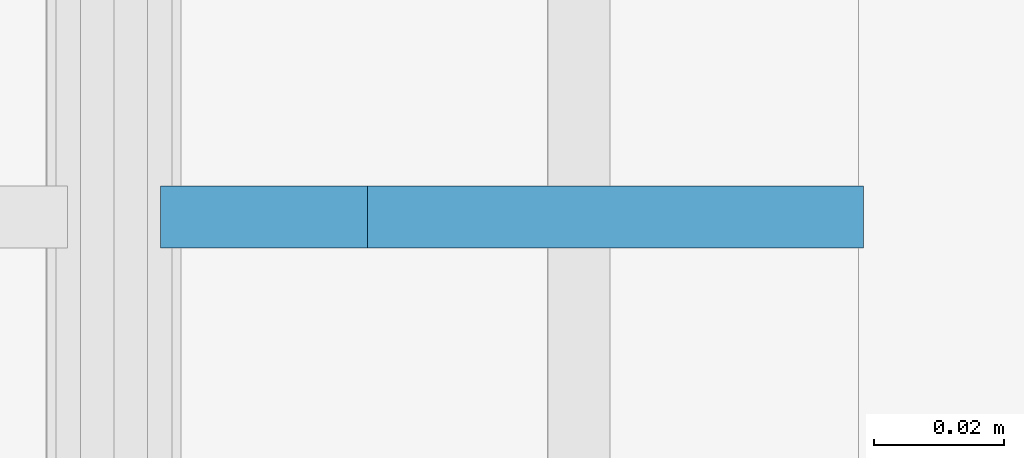
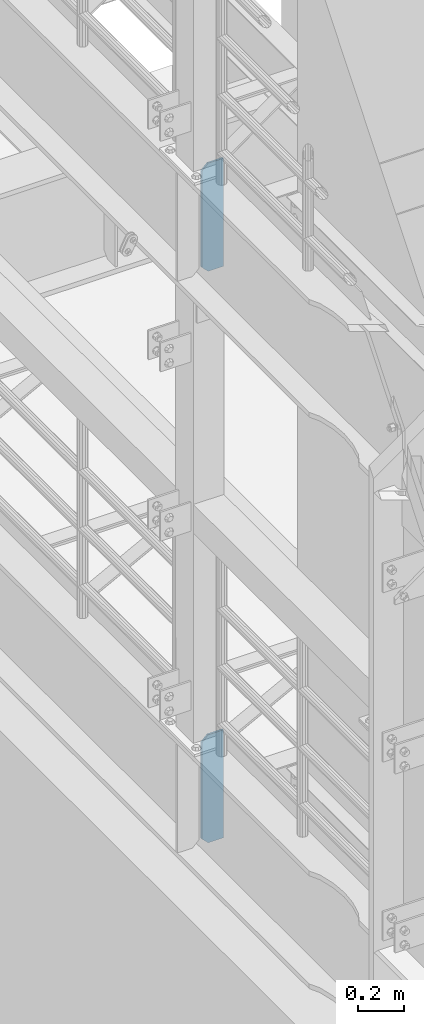
# One storey, part 1597 of 1876: 2 plates, 2 elements without a shape of their own.
"""IFC2X3 building model written with IfcOpenShell, lengths in millimetres."""

from ifc_helpers import new_model, si_unit, frame, origin_with_axes, place, context, subcontext, project, spatial, faceted_brep, material, type_object, element, aggregate, save


model = new_model("IFC2X3")

# Units and contexts
model_context = context("Model", 3, precision=1e-05, world=origin_with_axes())
body_context = subcontext(model_context, "Body", "Model", "MODEL_VIEW")
ifc_project = project(units=[si_unit("LENGTHUNIT", "METRE", prefix="MILLI"), si_unit("AREAUNIT", "SQUARE_METRE"), si_unit("VOLUMEUNIT", "CUBIC_METRE"), si_unit("MASSUNIT", "GRAM", prefix="KILO"), si_unit("TIMEUNIT", "SECOND"), si_unit("PLANEANGLEUNIT", "RADIAN"), si_unit("SOLIDANGLEUNIT", "STERADIAN"), si_unit("THERMODYNAMICTEMPERATUREUNIT", "DEGREE_CELSIUS"), si_unit("LUMINOUSINTENSITYUNIT", "LUMEN")], contexts=[model_context])

# Site, building, storey
site_placement = place(None, origin_with_axes())
site = spatial("IfcSite", under=ifc_project, at=site_placement, CompositionType="ELEMENT")
building_placement = place(site_placement, origin_with_axes())
building = spatial("IfcBuilding", under=site, at=building_placement, Name="Undefined", CompositionType="ELEMENT")
storey_placement = place(building_placement, origin_with_axes())
storey = spatial("IfcBuildingStorey", under=building, at=storey_placement, Name="Undefined", CompositionType="ELEMENT", Elevation=0.0)

# Assembly, plate
assembly_1_placement = place(storey_placement, origin_with_axes())
assembly_1 = element("IfcElementAssembly", 1, at=assembly_1_placement, inside=storey, Name="BEAM", AssemblyPlace="NOTDEFINED", PredefinedType="RIGID_FRAME")
ifc_material = material(Name="STEEL/A36")
plate_type = type_object("IfcPlateType", PredefinedType="NOTDEFINED")
plate_1_placement = place(assembly_1_placement, frame((115.09375, 3556.0, 7556.5), z_axis=(0.0, 0.0, 1.0), x_axis=(-1.0, 0.0, 0.0)))
plate_1 = element("IfcPlate", 2, at=plate_1_placement, type_object=plate_type, material=ifc_material, Name="PLATE", context=body_context, shape_type="Brep", body=[
    faceted_brep([(0.0, -4.76249999999982, 0.0), (0.0, -4.76249999999982, 571.5), (0.0, 4.76249999999982, 571.5), (0.0, 4.76249999999982, 0.0), (76.1999969482422, -4.76249999999982, 571.5), (76.1999969482422, 4.76249999999982, 571.5), (107.949996948242, -4.76249999999982, 539.75), (107.949996948242, 4.76249999999982, 539.75), (107.949996948242, -4.76249999999982, 31.75), (107.949996948242, 4.76249999999982, 31.75), (76.1999969482422, -4.76250000000073, 0.0), (76.1999969482422, 4.76250000000073, 0.0)], [[[0, 1, 2, 3]], [[1, 4, 5, 2]], [[4, 6, 7, 5]], [[6, 8, 9, 7]], [[8, 10, 11, 9]], [[10, 0, 3, 11]], [[5, 7, 9, 11, 3, 2]], [[10, 8, 6, 4, 1, 0]]]),
])
aggregate(assembly_1, [plate_1])

assembly_2_placement = place(storey_placement, origin_with_axes())
assembly_2 = element("IfcElementAssembly", 3, at=assembly_2_placement, inside=storey, Name="BEAM", AssemblyPlace="NOTDEFINED", PredefinedType="RIGID_FRAME")
plate_2_placement = place(assembly_2_placement, frame((115.09375, 3556.0, 4533.9), z_axis=(0.0, 0.0, 1.0), x_axis=(-1.0, 0.0, 0.0)))
plate_2 = element("IfcPlate", 4, at=plate_2_placement, type_object=plate_type, material=ifc_material, Name="PLATE", context=body_context, shape_type="Brep", body=[
    faceted_brep([(0.0, -4.76249999999982, 0.0), (0.0, -4.76249999999982, 571.5), (0.0, 4.76249999999982, 571.5), (0.0, 4.76249999999982, 0.0), (76.1999969482422, -4.76249999999982, 571.5), (76.1999969482422, 4.76249999999982, 571.5), (107.949996948242, -4.76249999999982, 539.75), (107.949996948242, 4.76249999999982, 539.75), (107.949996948242, -4.76249999999982, 31.75), (107.949996948242, 4.76249999999982, 31.75), (76.1999969482422, -4.76250000000073, 0.0), (76.1999969482422, 4.76250000000073, 0.0)], [[[0, 1, 2, 3]], [[1, 4, 5, 2]], [[4, 6, 7, 5]], [[6, 8, 9, 7]], [[8, 10, 11, 9]], [[10, 0, 3, 11]], [[5, 7, 9, 11, 3, 2]], [[10, 8, 6, 4, 1, 0]]]),
])
aggregate(assembly_2, [plate_2])

save(model, "model.ifc")
